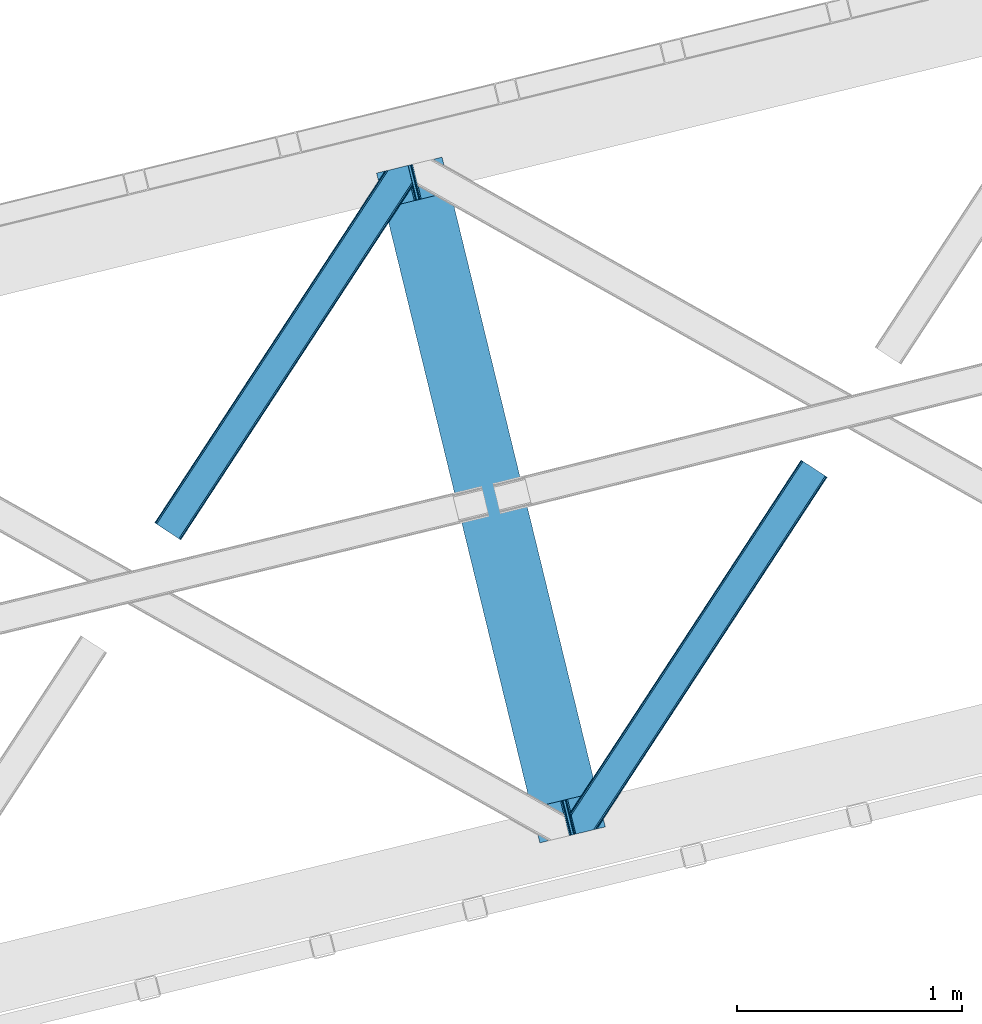
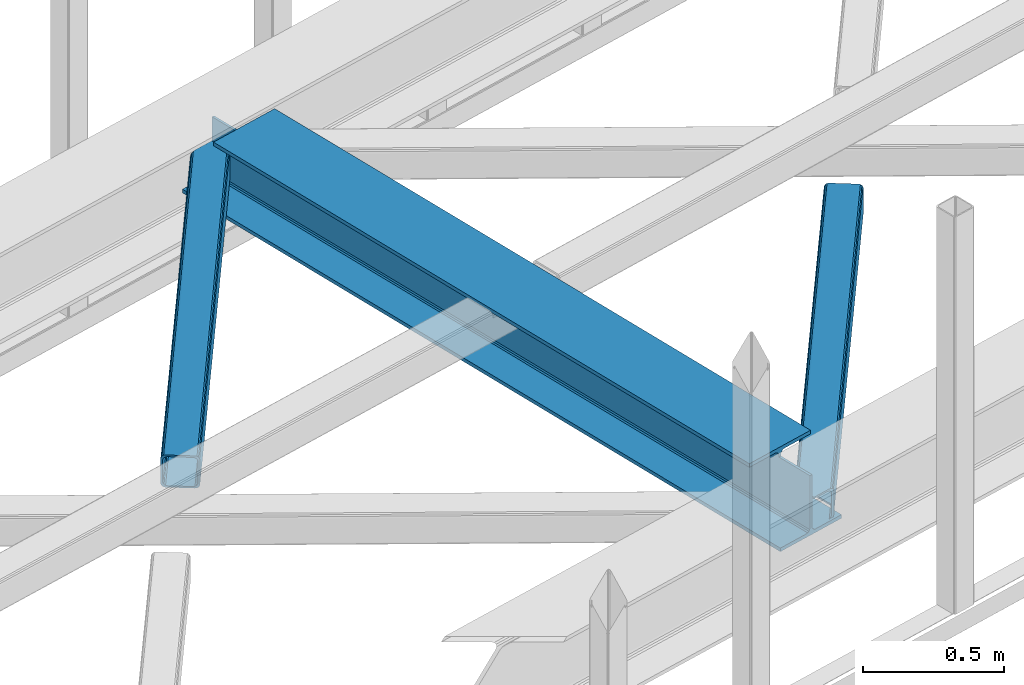
# One storey, part 33 of 66: 2 members, 1 beam.
"""IFC4 building model written with IfcOpenShell, lengths in millimetres."""

from ifc_helpers import new_model, entity, si_unit, converted_unit, derived_unit, direction, frame, origin, place, context, subcontext, project, spatial, triangles, polygons, material, type_object, element, save


model = new_model("IFC4")

# Units and contexts
model_context = context("Model", 3, precision=0.01, world=origin(), true_north=direction((6.12303176911189e-17, 1.0)))
plan_context = context("Plan", 3, precision=0.01, world=origin(), true_north=direction((6.12303176911189e-17, 1.0)))
body_context = subcontext(model_context, "Body", "Model", "MODEL_VIEW")
ifc_project = project(units=[si_unit("LENGTHUNIT", "METRE", prefix="MILLI"), si_unit("AREAUNIT", "SQUARE_METRE"), si_unit("VOLUMEUNIT", "CUBIC_METRE"), converted_unit("PLANEANGLEUNIT", "DEGREE", entity("IfcRatioMeasure", 0.0174532925199433), si_unit("PLANEANGLEUNIT", "RADIAN"), dimensions=[0, 0, 0, 0, 0, 0, 0]), si_unit("MASSUNIT", "GRAM", prefix="KILO"), derived_unit("MASSDENSITYUNIT", [(si_unit("MASSUNIT", "GRAM", prefix="KILO"), 1), (si_unit("LENGTHUNIT", "METRE"), -3)]), derived_unit("MOMENTOFINERTIAUNIT", [(si_unit("LENGTHUNIT", "METRE"), 4)]), si_unit("TIMEUNIT", "SECOND"), si_unit("FREQUENCYUNIT", "HERTZ"), si_unit("THERMODYNAMICTEMPERATUREUNIT", "DEGREE_CELSIUS"), derived_unit("THERMALTRANSMITTANCEUNIT", [(si_unit("MASSUNIT", "GRAM", prefix="KILO"), 1), (si_unit("THERMODYNAMICTEMPERATUREUNIT", "KELVIN"), -1), (si_unit("TIMEUNIT", "SECOND"), -3)]), derived_unit("VOLUMETRICFLOWRATEUNIT", [(si_unit("LENGTHUNIT", "METRE"), 3), (si_unit("TIMEUNIT", "SECOND"), -1)]), derived_unit("MASSFLOWRATEUNIT", [(si_unit("MASSUNIT", "GRAM", prefix="KILO"), 1), (si_unit("TIMEUNIT", "SECOND"), -1)]), derived_unit("ROTATIONALFREQUENCYUNIT", [(si_unit("TIMEUNIT", "SECOND"), -1)]), si_unit("ELECTRICCURRENTUNIT", "AMPERE"), si_unit("ELECTRICVOLTAGEUNIT", "VOLT"), si_unit("POWERUNIT", "WATT"), si_unit("FORCEUNIT", "NEWTON", prefix="KILO"), si_unit("ILLUMINANCEUNIT", "LUX"), si_unit("LUMINOUSFLUXUNIT", "LUMEN"), si_unit("LUMINOUSINTENSITYUNIT", "CANDELA"), derived_unit("USERDEFINED", [(si_unit("MASSUNIT", "GRAM", prefix="KILO"), -1), (si_unit("LENGTHUNIT", "METRE"), -2), (si_unit("TIMEUNIT", "SECOND"), 3), (si_unit("LUMINOUSFLUXUNIT", "LUMEN"), 1)]), derived_unit("LINEARVELOCITYUNIT", [(si_unit("LENGTHUNIT", "METRE"), 1), (si_unit("TIMEUNIT", "SECOND"), -1)]), si_unit("PRESSUREUNIT", "PASCAL"), derived_unit("USERDEFINED", [(si_unit("LENGTHUNIT", "METRE"), -2), (si_unit("MASSUNIT", "GRAM", prefix="KILO"), 1), (si_unit("TIMEUNIT", "SECOND"), -2)]), derived_unit("LINEARFORCEUNIT", [(si_unit("MASSUNIT", "GRAM", prefix="KILO"), 1), (si_unit("LENGTHUNIT", "METRE"), 1), (si_unit("TIMEUNIT", "SECOND"), -2), (si_unit("LENGTHUNIT", "METRE"), -1)]), derived_unit("PLANARFORCEUNIT", [(si_unit("MASSUNIT", "GRAM", prefix="KILO"), 1), (si_unit("LENGTHUNIT", "METRE"), 1), (si_unit("TIMEUNIT", "SECOND"), -2), (si_unit("LENGTHUNIT", "METRE"), -2)])], contexts=[model_context, plan_context])

# Site, building, storey
site_placement = place(None, origin())
site = spatial("IfcSite", under=ifc_project, at=site_placement, CompositionType="ELEMENT")
building_placement = place(site_placement, origin())
building = spatial("IfcBuilding", under=site, at=building_placement, CompositionType="ELEMENT")
storey_placement = place(building_placement, frame((0.0, 0.0, 19800.0)))
storey = spatial("IfcBuildingStorey", under=building, at=storey_placement, Name="06", CompositionType="ELEMENT", Elevation=19800.0)

# Beam
ifc_material = material(Name="Metal painted (White)")
beam_type = type_object("IfcBeamType", PredefinedType="BEAM")
beam_placement = place(storey_placement, frame((-36668.69, 8856.55, 3808.0)))
element("IfcBeam", 1, at=beam_placement, inside=storey, type_object=beam_type, material=ifc_material, ObjectType="Steel Beam", PredefinedType="BEAM", context=body_context, shape_type="Tessellation", body=[
    polygons([(1018.16648378329, 71.0478278970989, 15.5000000000051), (1018.16648378329, 71.047827897101, 0.0), (291.465617442442, 3052.25531830421, 0.0), (291.465617442442, 3052.25531830421, 15.5000000000051), (894.779372399325, 40.9709140873259, 15.5000000000051), (168.078506058478, 3022.17840449444, 15.5000000000051), (888.087028625366, 39.339584488821, 16.8701684148028), (161.386162284515, 3020.54707489593, 16.8701684148028), (882.413533524746, 37.9566100336497, 20.7720779386478), (155.7126671839, 3019.16410044076, 20.7720779386478), (878.622625296176, 37.0325360459173, 26.6116982174338), (151.921758955325, 3018.24002645303, 26.6116982174338), (877.291435352775, 36.7080444135018, 33.500000000001), (150.590569011928, 3017.91553482061, 33.500000000001), (140.875048430514, 3015.54727389071, 33.500000000001), (140.875048430518, 3015.54727389071, 259.000000000006), (150.590569011928, 3017.91553482061, 259.000000000006), (0.0, 2981.20749040711, 4.33146851719357e-12), (0.0, 2981.20749040711, 15.5000000000051), (123.387111383968, 3011.28440421688, 15.5000000000051), (130.079455157922, 3012.91573381539, 16.8701684148028), (135.752950258546, 3014.29870827056, 20.7720779386478), (139.543858487122, 3015.22278225829, 26.6116982174338), (877.291435352775, 36.7080444135018, 259.000000000006), (867.57591477136, 34.3397834836003, 259.000000000006), (867.57591477136, 34.3397834835981, 33.500000000001), (866.244724827968, 34.0152918511837, 26.6116982174338), (862.453816599393, 33.0912178634492, 20.7720779386478), (856.780321498777, 31.7082434082767, 16.8701684148028), (850.087977724815, 30.076913809773, 15.5000000000051), (726.700866340847, 0.0, 15.5000000000051), (726.700866340847, 0.0, 4.33146851719357e-12), (839.723099725409, 190.827961666225, 259.069792599954), (188.068298227652, 2864.16742161973, 259.000000000006), (188.291691329497, 2863.25097721476, 259.617303331129), (188.304080173126, 2863.20015298098, 266.500003008253), (839.577920935828, 191.423439609248, 266.500002998871), (839.578271056576, 191.422003304514, 260.000004007593), (830.098162489501, 188.087889491629, 259.00634317046), (829.874792453792, 189.004341089458, 259.617303331129), (829.862403610162, 189.055165323231, 266.500003008253), (178.588562847465, 2860.83187869496, 266.500002998871), (178.588212726713, 2860.8333149997, 260.000004007593), (178.443407068373, 2861.42736381349, 259.076120467494), (178.352777646233, 2861.79916068982, 259.000000000006), (840.909408805751, 191.746709053933, 273.388305639792), (844.699685394443, 192.673374225847, 279.227924098781), (850.372756341981, 194.058088689524, 283.129832400619), (857.064948023115, 195.690042220337, 284.500000377228), (980.451976710954, 225.767295275449, 284.500000138975), (980.450306904298, 225.77414534418, 299.999995328161), (688.984884807028, 154.725516080138, 299.999995890966), (688.98655461368, 154.718666011407, 284.500000701776), (812.373583301528, 184.795919066517, 284.500000463524), (819.066070197671, 186.426661533095, 283.129832461069), (824.739981846423, 187.80792717762, 279.227924137327), (828.531516633419, 188.729430826919, 273.388305663689), (177.257074977538, 2860.50860925028, 273.388305639792), (173.46679838885, 2859.58194407836, 279.227924098781), (167.793727441316, 2858.19722961469, 283.129832400619), (161.101535760182, 2856.56527608387, 284.500000377228), (37.7145070723341, 2826.48802302876, 284.500000138975), (37.7161768789945, 2826.48117296003, 299.999995328161), (329.18159897626, 2897.52980222407, 299.999995890962), (329.179929169609, 2897.5366522928, 284.500000701776), (205.79290048176, 2867.45939923769, 284.500000463524), (199.100413585622, 2865.82865677111, 283.129832461069), (193.426501936866, 2864.44739112659, 279.227924137327), (189.63496714987, 2863.52588747729, 273.388305663689)], [[[1, 2, 3, 4]], [[5, 1, 4, 6]], [[7, 5, 6, 8]], [[9, 7, 8, 10]], [[11, 9, 10, 12]], [[13, 11, 12, 14]], [[15, 16, 17, 14, 12, 10, 8, 6, 4, 3, 18, 19, 20, 21, 22, 23]], [[13, 24, 25, 26, 27, 28, 29, 30, 31, 32, 2, 1, 5, 7, 9, 11]], [[2, 32, 18, 3]], [[32, 31, 19, 18]], [[31, 30, 20, 19]], [[27, 26, 15, 23]], [[28, 27, 23, 22]], [[29, 28, 22, 21]], [[30, 29, 21, 20]], [[33, 24, 13, 14, 17, 34, 35, 36, 37, 38]], [[25, 39, 40, 41, 42, 43, 44, 16, 15, 26]], [[39, 25, 24, 33]], [[45, 34, 17, 16]], [[41, 40, 38, 37, 46, 47, 48, 49, 50, 51, 52, 53, 54, 55, 56, 57]], [[42, 58, 59, 60, 61, 62, 63, 64, 65, 66, 67, 68, 69, 36, 35, 43]], [[46, 37, 36, 69]], [[47, 46, 69, 68]], [[48, 47, 68, 67]], [[49, 48, 67, 66]], [[50, 49, 66, 65]], [[51, 50, 65, 64]], [[52, 51, 64, 63]], [[53, 52, 63, 62]], [[54, 53, 62, 61]], [[55, 54, 61, 60]], [[56, 55, 60, 59]], [[57, 56, 59, 58]], [[41, 57, 58, 42]]], closed=False),
])

# Members
member_type_1 = type_object("IfcMemberType", PredefinedType="BRACE")
member_1_placement = place(storey_placement, frame((-37656.9, 10204.55, 3824.0)))
element("IfcMember", 2, at=member_1_placement, inside=storey, type_object=member_type_1, ObjectType="Steel Horizontal Brace", PredefinedType="BRACE", context=body_context, shape_type="Tessellation", body=[
    triangles([(994.774163818358, 1564.02662658691, 0.0), (1028.82324829102, 1424.34678039551, 0.0), (14.643292236331, 67.1040435791019, 0.0), (102.486767578128, 9.58662414550781, 0.0), (1.1162109375, 75.9604797363281, 10.8039916992202), (0.0, 76.6895050048824, 17.5012573242202), (1025.02813110351, 1642.17883300781, 17.5012573242202), (4.29043579101563, 73.8826995849613, 5.12526855468968), (990.476751708986, 1585.87645568848, 9.49942016601563), (990.046545410158, 1584.44747314453, 8.74132690429906), (989.90701904297, 1583.99168701172, 8.49948120117188), (990.762780761717, 1580.48841247559, 5.12526855468968), (1027.31171264649, 1642.73461303711, 10.8691040039084), (1027.78377685547, 1642.84972229004, 9.49942016601563), (992.602203369141, 1572.93538513184, 1.33247680664135), (9.04130859374709, 70.7724243164066, 1.33247680664135), (1025.02813110351, 1642.17883300781, 122.499499511719), (0.0, 76.6895050048824, 122.499499511719), (1026.92336425781, 1642.64043273926, 129.196765136719), (1.1162109375, 75.9604797363281, 129.196765136719), (1032.31838378906, 1643.95546875, 134.87548828125), (4.29043579101563, 73.8826995849613, 134.87548828125), (1040.39463500977, 1645.92395324707, 138.668280029298), (9.04130859374709, 70.7724243164066, 138.668280029298), (1049.91963500976, 1648.24590454102, 140.00075683594), (14.643292236331, 67.1040435791019, 140.00075683594), (994.871832275392, 1567.85081176758, 9.49942016601563), (994.762536621092, 1567.00667724609, 9.2947814941399), (994.650915527345, 1566.15091552734, 9.08781738281323), (994.541619873045, 1565.30561828613, 8.8831787109375), (994.746258544925, 1564.1440612793, 8.49948120117188), (1047.05469360352, 1647.54827270508, 9.49942016601563), (14.8967651367202, 66.9377746582031, 8.3320495605476), (20.4987487792969, 63.2693939208984, 6.99957275390625), (997.043792724609, 1554.71440429688, 6.99957275390625), (10.1458923339815, 70.0480499267578, 12.1248413085959), (1042.27591552735, 1646.38322753906, 12.1248413085959), (1036.87857055664, 1645.06702880859, 17.8035644531265), (1034.9856628418, 1644.60542907715, 24.5008300781265), (6.97166748046584, 72.1258300781246, 17.8035644531265), (5.85778198242042, 72.8548553466808, 24.5008300781265), (1026.55361938477, 1433.65900268555, 6.99957275390625), (96.6313110351548, 13.420111083984, 6.99957275390625), (1028.71860351563, 1424.77582397461, 8.41343994140698), (1032.83695678711, 1407.88615722656, 5.12526855468968), (1033.6903930664, 1404.3817199707, 8.49948120117188), (1030.99520874023, 1415.43918457031, 1.33247680664135), (1034.9856628418, 1644.60542907715, 115.499926757813), (5.85778198242042, 72.8548553466808, 115.499926757813), (1050.34984130859, 1648.35171203613, 131.668707275392), (1059.87716674805, 1650.67366333008, 133.001184082033), (20.4987487792969, 63.2693939208984, 133.001184082033), (14.8967651367202, 66.9377746582031, 131.668707275392), (1042.27591552735, 1646.38322753906, 127.873590087893), (10.1458923339815, 70.0480499267578, 127.873590087893), (1036.87857055664, 1645.06702880859, 122.197192382813), (6.97166748046584, 72.1258300781246, 122.197192382813), (1128.10788574219, 1667.30520629883, 140.00075683594), (1128.10788574219, 1667.30520629883, 133.001184082033), (1144.33015136719, 1600.75810546875, 140.00075683594), (102.486767578128, 9.58662414550781, 140.00075683594), (1142.06052246094, 1610.06916503906, 133.001184082033), (96.6313110351548, 13.420111083984, 133.001184082033), (1146.50211181641, 1591.84934692383, 138.668280029298), (108.088751220705, 5.91708068847765, 138.668280029298), (1148.34385986328, 1584.29631958008, 134.87548828125), (112.839624023436, 2.80796813964844, 134.87548828125), (1149.57401733399, 1579.2501159668, 129.196765136719), (116.013848876952, 0.729025268554324, 129.196765136719), (1150.00422363282, 1577.47813110352, 122.499499511719), (117.127734374997, 0.0, 122.499499511719), (1150.00422363282, 1577.47813110352, 17.5012573242202), (117.127734374997, 0.0, 17.5012573242202), (106.98416748047, 6.64261779785193, 127.873590087893), (110.156066894531, 4.56367492675781, 122.197192382813), (111.269952392577, 3.83464965820349, 115.499926757813), (102.233294677731, 9.75173034667932, 131.668707275392), (116.013848876952, 0.729025268554324, 10.8039916992202), (106.98416748047, 6.64261779785193, 12.1248413085959), (112.839624023436, 2.80796813964844, 5.12526855468968), (111.269952392577, 3.83464965820349, 24.5008300781265), (110.156066894531, 4.56367492675781, 17.8035644531265), (108.088751220705, 5.91708068847765, 1.33247680664135), (102.233294677731, 9.75173034667932, 8.3320495605476), (1147.30438842774, 1588.56233825684, 122.197192382813), (1147.73459472656, 1586.78919067383, 115.499926757813), (1146.07423095703, 1593.60854187012, 127.873590087893), (1144.23248291016, 1601.16040649414, 131.668707275392), (1147.73459472656, 1586.78919067383, 24.5008300781265), (1147.21602172851, 1588.9239440918, 17.8686767578147), (1149.994921875, 1577.51650085449, 16.5013183593765), (1147.10672607422, 1589.36461486816, 16.5013183593765), (1145.27893066406, 1573.10863037109, 10.8714294433594), (1034.62056884765, 1404.78750915527, 9.49942016601563), (1144.12783813477, 1572.03427734375, 9.49942016601563), (1142.79303588867, 1588.59721984863, 12.1248413085959), (1030.22548828125, 1422.8143157959, 9.49942016601563), (1029.19764404297, 1423.6724029541, 8.80643920898365), (1139.73275756836, 1590.05992126465, 9.49942016601563)], [[1, 2, 3], [4, 3, 2], [5, 6, 7], [8, 9, 10], [11, 12, 8], [5, 13, 9], [9, 8, 5], [13, 14, 9], [15, 1, 16], [3, 16, 1], [12, 15, 8], [16, 8, 15], [7, 13, 5], [17, 7, 6], [6, 18, 17], [19, 17, 20], [18, 20, 17], [21, 19, 22], [20, 22, 19], [23, 21, 24], [22, 24, 21], [25, 23, 26], [24, 26, 23], [27, 28, 9], [28, 29, 10], [29, 30, 10], [30, 31, 11], [14, 32, 27], [27, 9, 14], [33, 34, 35], [36, 33, 31], [31, 30, 36], [28, 36, 29], [28, 27, 36], [36, 30, 29], [32, 37, 27], [36, 27, 37], [35, 31, 33], [38, 39, 40], [41, 40, 39], [37, 38, 36], [40, 36, 38], [42, 35, 34], [34, 43, 42], [1, 35, 42], [31, 12, 11], [1, 31, 35], [31, 15, 12], [31, 1, 15], [2, 1, 42], [44, 2, 42], [45, 44, 46], [44, 47, 2], [44, 45, 47], [39, 48, 49], [49, 41, 39], [50, 51, 52], [52, 53, 50], [54, 50, 53], [53, 55, 54], [56, 54, 55], [55, 57, 56], [48, 56, 57], [57, 49, 48], [56, 17, 19], [50, 23, 25], [58, 51, 25], [51, 58, 59], [51, 50, 25], [54, 23, 50], [54, 56, 21], [21, 23, 54], [19, 21, 56], [39, 7, 17], [37, 14, 38], [56, 48, 17], [37, 32, 14], [39, 38, 7], [48, 39, 17], [13, 7, 38], [38, 14, 13], [60, 25, 61], [25, 60, 58], [26, 61, 25], [51, 62, 63], [51, 59, 62], [63, 52, 51], [64, 60, 61], [61, 65, 64], [66, 64, 65], [65, 67, 66], [68, 66, 67], [67, 69, 68], [70, 68, 69], [69, 71, 70], [72, 70, 71], [71, 73, 72], [69, 74, 75], [76, 73, 71], [69, 75, 71], [69, 67, 74], [75, 76, 71], [74, 67, 65], [63, 61, 26], [61, 77, 65], [77, 61, 63], [77, 74, 65], [78, 79, 80], [81, 73, 76], [73, 82, 78], [82, 73, 81], [78, 82, 79], [4, 43, 3], [83, 80, 79], [79, 84, 83], [84, 43, 4], [4, 83, 84], [55, 24, 22], [26, 52, 63], [26, 53, 52], [53, 26, 24], [55, 53, 24], [49, 18, 6], [20, 57, 55], [22, 20, 55], [57, 20, 18], [49, 57, 18], [16, 36, 8], [3, 43, 34], [34, 33, 3], [33, 36, 16], [16, 3, 33], [5, 8, 36], [6, 41, 49], [40, 6, 5], [6, 40, 41], [40, 5, 36], [85, 86, 75], [76, 75, 86], [87, 85, 74], [75, 74, 85], [88, 87, 77], [74, 77, 87], [62, 88, 63], [77, 63, 88], [86, 89, 76], [81, 76, 89], [90, 91, 92], [70, 72, 89], [72, 90, 89], [89, 86, 70], [72, 91, 90], [85, 70, 86], [68, 70, 85], [66, 85, 87], [85, 66, 68], [87, 64, 66], [88, 64, 87], [88, 62, 60], [88, 60, 64], [62, 58, 60], [62, 59, 58], [73, 78, 93], [93, 72, 73], [94, 93, 78], [94, 95, 93], [80, 45, 46], [46, 78, 80], [46, 94, 78], [47, 45, 83], [80, 83, 45], [2, 47, 4], [83, 4, 47], [93, 91, 72], [82, 81, 89], [82, 92, 96], [82, 90, 92], [84, 97, 98], [79, 96, 97], [97, 84, 79], [96, 99, 97], [43, 84, 44], [44, 42, 43], [96, 79, 82], [89, 90, 82], [96, 91, 93], [96, 92, 91], [96, 95, 99], [93, 95, 96], [99, 95, 97], [94, 97, 95]]),
])
member_type_2 = type_object("IfcMemberType", PredefinedType="BRACE")
member_2_placement = place(storey_placement, frame((-35805.58, 8895.62, 3824.0)))
element("IfcMember", 3, at=member_2_placement, inside=storey, type_object=member_type_2, ObjectType="Steel Horizontal Brace", PredefinedType="BRACE", context=body_context, shape_type="Tessellation", body=[
    triangles([(109.770043945318, 259.949830627442, 7.52047119140843), (115.030187988283, 238.365682983398, 7.77626953125218), (114.216284179689, 239.946981811523, 8.3320495605476), (108.809637451173, 259.662638854981, 8.52041015625218), (113.637249755862, 239.859777832031, 8.52041015625218), (112.20710449219, 237.677352905273, 8.52041015625218), (91.0339782714873, 232.516621398925, 8.52041015625218), (109.535174560551, 237.025648498535, 9.49942016601563), (90.2619323730469, 232.328260803222, 9.49942016601563), (5.0206237793027, 77.405158996582, 9.49942016601563), (0.625543212896446, 95.4308029174808, 9.49942016601563), (1046.62216186523, 1651.75382995605, 6.99957275390625), (1041.02017822266, 1655.42221069336, 8.3320495605476), (116.699853515631, 231.514938354492, 6.99957275390625), (1036.26930541993, 1658.53132324219, 12.1248413085959), (3.92999267578125, 81.8752349853512, 12.1248413085959), (1033.09740600587, 1660.61026611328, 17.8035644531265), (2.69983520507958, 86.9220199584961, 17.8035644531265), (1031.98352050781, 1661.34045410156, 24.5008300781265), (2.26962890625146, 88.6940048217766, 24.5008300781265), (1122.7547241211, 1601.90454711914, 6.99957275390625), (146.209680175787, 110.459536743165, 6.99957275390625), (1031.98352050781, 1661.34045410156, 115.499926757813), (2.26962890625146, 88.6940048217766, 115.499926757813), (1033.09740600587, 1660.61026611328, 122.197192382813), (2.69983520507958, 86.9220199584961, 122.197192382813), (1036.26930541993, 1658.53132324219, 127.873590087893), (3.92999267578125, 81.8752349853512, 127.873590087893), (1041.02017822266, 1655.42221069336, 131.668707275392), (5.77174072265916, 74.3227890014641, 131.668707275392), (1046.62216186523, 1651.75382995605, 133.001184082033), (7.94370117187646, 65.4140304565426, 133.001184082033), (1027.24194946289, 1664.44491577148, 10.8039916992202), (0.518572998051241, 95.8714736938473, 10.8691040039084), (0.0, 98.0056457519531, 17.5012573242202), (1035.16472167969, 1659.25686035156, 1.33247680664135), (112.260589599609, 249.73533782959, 1.33247680664135), (110.544415283206, 256.772117614746, 5.59500732422021), (109.077062988283, 259.839372253418, 8.32042236328198), (1030.41384887695, 1662.36597290039, 5.12526855468968), (1040.76670532227, 1655.58847961426, 0.0), (114.430224609379, 240.826579284669, 0.0), (1026.12573852539, 1665.17394104004, 17.5012573242202), (1128.61250610352, 1598.06989746094, 0.0), (148.479309082031, 101.147314453125, 0.0), (150.651269531256, 92.2385559082031, 1.33247680664135), (148.507214355472, 101.029298400879, 8.49948120117188), (152.493017578126, 84.686109924316, 5.12526855468968), (153.346453857426, 81.182254028321, 8.49948120117188), (1026.12573852539, 1665.17394104004, 122.499499511719), (0.0, 98.0056457519531, 122.499499511719), (1040.76670532227, 1655.58847961426, 140.00075683594), (1035.16472167969, 1659.25686035156, 138.668280029298), (3.50211181640771, 83.6350112915043, 138.668280029298), (5.674072265625, 74.7256713867191, 140.00075683594), (1030.41384887695, 1662.36597290039, 134.87548828125), (1.66036376953707, 91.1874572753914, 134.87548828125), (1027.24194946289, 1664.44491577148, 129.196765136719), (0.430206298828125, 96.2336608886726, 129.196765136719), (23.8892395019575, 0.0, 140.00075683594), (23.8892395019575, 0.0, 133.001184082033), (1128.61250610352, 1598.06989746094, 140.00075683594), (93.3338378906265, 16.9280364990227, 140.00075683594), (1122.7547241211, 1601.90454711914, 133.001184082033), (83.3786315917969, 14.5008590698235, 133.001184082033), (1143.2534729004, 1588.48443603516, 122.499499511719), (1142.1372619629, 1589.21346130371, 129.196765136719), (118.225341796875, 22.9951080322262, 122.499499511719), (116.330108642578, 22.5335083007813, 129.196765136719), (1138.96536254883, 1591.29124145508, 134.87548828125), (110.935089111328, 21.2178909301765, 134.87548828125), (1134.2144897461, 1594.40151672363, 138.668280029298), (102.861163330082, 19.2499877929695, 138.668280029298), (1143.2534729004, 1588.48443603516, 17.5012573242202), (118.225341796875, 22.9951080322262, 17.5012573242202), (1142.1372619629, 1589.21346130371, 10.8039916992202), (1133.10758056641, 1595.12589111328, 12.1248413085959), (1136.28180541992, 1593.04811096191, 17.8035644531265), (1137.39569091797, 1592.31792297363, 24.5008300781265), (1138.96536254883, 1591.29124145508, 5.12526855468968), (1134.2144897461, 1594.40151672363, 1.33247680664135), (1128.35903320313, 1598.23616638184, 8.3320495605476), (1133.10758056641, 1595.12589111328, 127.873590087893), (1137.39569091797, 1592.31792297363, 115.499926757813), (1136.28180541992, 1593.04811096191, 122.197192382813), (1128.35903320313, 1598.23616638184, 131.668707275392), (92.9036315917983, 16.8228103637703, 131.668707275392), (100.977557373051, 18.7912948608391, 127.873590087893), (106.372576904301, 20.106330871582, 122.197192382813), (108.267810058598, 20.5685119628906, 115.499926757813), (108.267810058598, 20.5685119628906, 24.5008300781265), (100.977557373051, 18.7912948608391, 12.1248413085959), (115.472021484376, 22.32421875, 9.49942016601563), (106.372576904301, 20.106330871582, 17.8035644531265), (96.1987792968794, 17.6262496948239, 9.49942016601563), (115.944085693365, 22.439328002929, 10.8691040039084), (153.060424804688, 80.2392883300781, 8.99945068359375), (152.776721191411, 79.2969039916989, 9.49942016601563), (148.711853027344, 99.8677413940422, 8.8831787109375), (148.602557373051, 99.023606872559, 9.08781738281323), (148.490936279297, 98.1666824340828, 9.2947814941399), (148.381640625004, 97.3231292724613, 9.49942016601563)], [[1, 2, 3], [4, 5, 6], [6, 7, 4], [7, 6, 8], [8, 9, 7], [9, 8, 10], [10, 11, 9], [12, 13, 3], [3, 2, 12], [2, 14, 12], [15, 16, 8], [8, 13, 15], [8, 5, 13], [16, 10, 8], [8, 6, 5], [15, 17, 18], [18, 16, 15], [17, 19, 20], [20, 18, 17], [21, 12, 14], [14, 22, 21], [19, 23, 20], [24, 20, 23], [23, 25, 24], [26, 24, 25], [25, 27, 26], [28, 26, 27], [27, 29, 28], [30, 28, 29], [29, 31, 30], [32, 30, 31], [33, 34, 35], [36, 37, 38], [33, 4, 9], [33, 1, 39], [9, 34, 33], [9, 11, 34], [4, 7, 9], [40, 38, 1], [1, 33, 40], [38, 40, 36], [36, 41, 37], [42, 37, 41], [35, 43, 33], [41, 44, 42], [45, 42, 44], [14, 42, 22], [37, 2, 38], [2, 37, 42], [38, 2, 1], [42, 14, 2], [22, 42, 45], [46, 47, 45], [47, 46, 48], [45, 47, 22], [48, 49, 47], [50, 43, 35], [35, 51, 50], [52, 53, 54], [54, 55, 52], [53, 56, 57], [57, 54, 53], [56, 58, 59], [59, 57, 56], [58, 50, 51], [51, 59, 58], [28, 57, 26], [30, 32, 55], [32, 60, 55], [32, 61, 60], [54, 30, 55], [28, 54, 57], [16, 11, 10], [28, 30, 54], [51, 35, 20], [24, 26, 51], [24, 51, 20], [57, 59, 26], [26, 59, 51], [35, 18, 20], [18, 11, 16], [11, 18, 34], [35, 34, 18], [62, 55, 63], [62, 52, 55], [55, 60, 63], [64, 32, 31], [32, 64, 65], [61, 32, 65], [66, 67, 68], [69, 68, 67], [67, 70, 69], [71, 69, 70], [70, 72, 71], [73, 71, 72], [72, 62, 73], [63, 73, 62], [74, 66, 75], [68, 75, 66], [76, 77, 78], [79, 66, 74], [76, 78, 74], [76, 80, 77], [78, 79, 74], [77, 80, 81], [21, 44, 41], [44, 82, 81], [82, 44, 21], [82, 77, 81], [67, 83, 70], [84, 66, 79], [66, 85, 67], [85, 66, 84], [67, 85, 83], [62, 64, 52], [72, 70, 83], [83, 86, 72], [86, 64, 62], [62, 72, 86], [15, 36, 40], [41, 12, 21], [41, 13, 12], [13, 41, 36], [15, 13, 36], [19, 43, 50], [33, 17, 15], [40, 33, 15], [17, 33, 43], [19, 17, 43], [53, 27, 56], [52, 64, 31], [31, 29, 52], [29, 27, 53], [53, 52, 29], [58, 56, 27], [50, 23, 19], [25, 50, 58], [50, 25, 23], [25, 58, 27], [64, 86, 87], [87, 65, 64], [86, 83, 88], [88, 87, 86], [83, 85, 89], [89, 88, 83], [85, 84, 90], [90, 89, 85], [84, 79, 91], [91, 90, 84], [89, 68, 69], [87, 73, 63], [60, 65, 63], [65, 60, 61], [65, 87, 63], [88, 73, 87], [88, 89, 71], [71, 73, 88], [69, 71, 89], [91, 75, 68], [92, 93, 94], [89, 90, 68], [92, 95, 93], [91, 94, 75], [90, 91, 68], [96, 75, 94], [94, 93, 96], [76, 74, 75], [49, 80, 97], [98, 97, 80], [49, 48, 80], [76, 96, 98], [98, 80, 76], [96, 93, 98], [44, 81, 45], [46, 45, 81], [81, 80, 46], [48, 46, 80], [75, 96, 76], [82, 21, 22], [77, 82, 47], [47, 99, 77], [77, 100, 101], [100, 77, 99], [101, 102, 77], [77, 102, 92], [95, 92, 102], [22, 47, 82], [79, 78, 91], [94, 91, 78], [78, 77, 94], [92, 94, 77], [102, 101, 98], [101, 100, 97], [100, 99, 49], [99, 47, 49], [102, 98, 93], [93, 95, 102]]),
])

save(model, "model.ifc")
